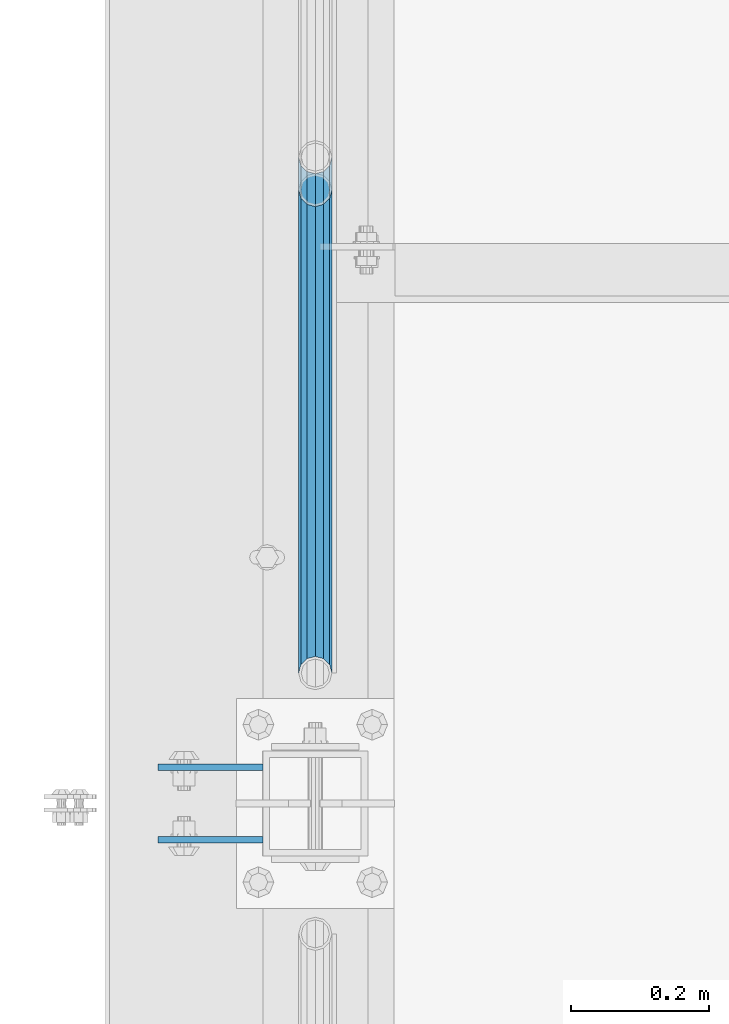
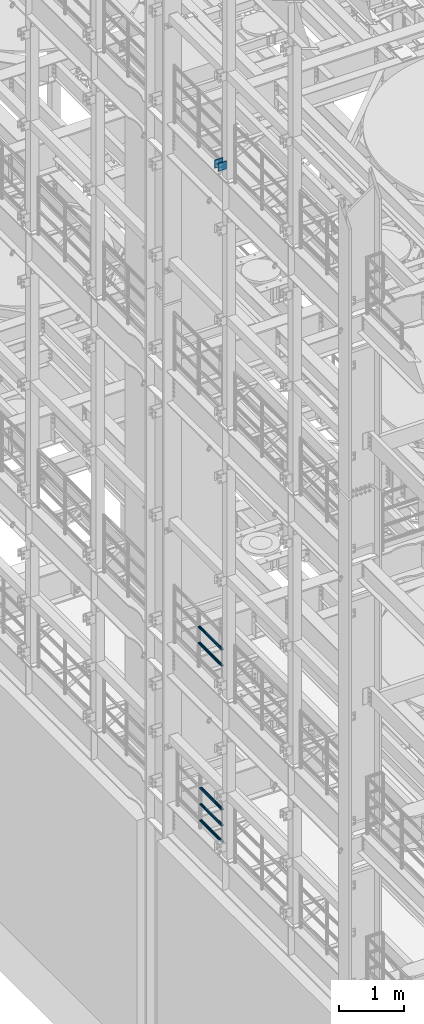
# One storey, part 1231 of 1876: 7 beams, 3 elements without a shape of their own.
"""IFC2X3 building model written with IfcOpenShell, lengths in millimetres."""

from ifc_helpers import new_model, si_unit, frame, origin_with_axes, place, context, subcontext, project, spatial, faceted_brep, material, type_object, element, aggregate, save


model = new_model("IFC2X3")

# Units and contexts
model_context = context("Model", 3, precision=1e-05, world=origin_with_axes())
body_context = subcontext(model_context, "Body", "Model", "MODEL_VIEW")
ifc_project = project(units=[si_unit("LENGTHUNIT", "METRE", prefix="MILLI"), si_unit("AREAUNIT", "SQUARE_METRE"), si_unit("VOLUMEUNIT", "CUBIC_METRE"), si_unit("MASSUNIT", "GRAM", prefix="KILO"), si_unit("TIMEUNIT", "SECOND"), si_unit("PLANEANGLEUNIT", "RADIAN"), si_unit("SOLIDANGLEUNIT", "STERADIAN"), si_unit("THERMODYNAMICTEMPERATUREUNIT", "DEGREE_CELSIUS"), si_unit("LUMINOUSINTENSITYUNIT", "LUMEN")], contexts=[model_context])

# Site, building, storey
site_placement = place(None, origin_with_axes())
site = spatial("IfcSite", under=ifc_project, at=site_placement, CompositionType="ELEMENT")
building_placement = place(site_placement, origin_with_axes())
building = spatial("IfcBuilding", under=site, at=building_placement, Name="Undefined", CompositionType="ELEMENT")
storey_placement = place(building_placement, origin_with_axes())
storey = spatial("IfcBuildingStorey", under=building, at=storey_placement, Name="Undefined", CompositionType="ELEMENT", Elevation=0.0)

# Assembly, beams
assembly_1_placement = place(storey_placement, origin_with_axes())
assembly_1 = element("IfcElementAssembly", 1, at=assembly_1_placement, inside=storey, Name="BEAM", AssemblyPlace="NOTDEFINED", PredefinedType="RIGID_FRAME")
ifc_material_1 = material(Name="STEEL/A36")
beam_type_1 = type_object("IfcBeamType", PredefinedType="NOTDEFINED")
beam_1_placement = place(assembly_1_placement, frame((-76.2000002548894, -455.6125, 18275.3), z_axis=(0.0, 0.0, -1.0), x_axis=(-1.0, 0.0, 0.0)))
beam_1 = element("IfcBeam", 2, at=beam_1_placement, type_object=beam_type_1, material=ifc_material_1, Name="PLATE", context=body_context, shape_type="Brep", body=[
    faceted_brep([(0.0, 4.76249999999982, -76.1999999999998), (3.63797880709171e-12, 4.76249999999982, 76.1999969482422), (152.399993896484, 4.76250000000073, 76.1999969482422), (152.4, 4.76249999999982, -76.1999999999998), (3.63797880709171e-12, -4.76249999999982, 76.1999969482422), (152.399993896484, -4.76250000000073, 76.1999969482422), (0.0, -4.76249999999982, -76.1999999999998), (152.4, -4.76249999999982, -76.1999999999998)], [[[0, 1, 2, 3]], [[4, 5, 2, 1]], [[4, 6, 7, 5]], [[6, 0, 3, 7]], [[5, 7, 3, 2]], [[6, 4, 1, 0]]]),
])
beam_2_placement = place(assembly_1_placement, frame((-76.2000002548894, -560.3875, 18275.3), z_axis=(0.0, 0.0, -1.0), x_axis=(-1.0, 0.0, 0.0)))
beam_2 = element("IfcBeam", 3, at=beam_2_placement, type_object=beam_type_1, material=ifc_material_1, Name="PLATE", context=body_context, shape_type="Brep", body=[
    faceted_brep([(0.0, 4.76249999999982, -76.1999999999998), (3.63797880709171e-12, 4.76249999999982, 76.1999969482422), (152.399993896484, 4.76250000000073, 76.1999969482422), (152.4, 4.76249999999982, -76.1999999999998), (3.63797880709171e-12, -4.76249999999982, 76.1999969482422), (152.399993896484, -4.76250000000073, 76.1999969482422), (0.0, -4.76249999999982, -76.1999999999998), (152.4, -4.76249999999982, -76.1999999999998)], [[[0, 1, 2, 3]], [[4, 5, 2, 1]], [[4, 6, 7, 5]], [[6, 0, 3, 7]], [[5, 7, 3, 2]], [[6, 4, 1, 0]]]),
])
aggregate(assembly_1, [beam_1, beam_2])

assembly_2_placement = place(storey_placement, origin_with_axes())
assembly_2 = element("IfcElementAssembly", 4, at=assembly_2_placement, inside=storey, Name="RAIL", AssemblyPlace="NOTDEFINED", PredefinedType="RIGID_FRAME")
ifc_material_2 = material()
beam_type_2 = type_object("IfcBeamType", Name="PIPE1-1/2SCH40", PredefinedType="NOTDEFINED")
beam_3_placement = place(assembly_2_placement, frame((-1.81898940354586e-12, -318.770000000001, 8620.125), z_axis=(0.0, 0.0, -1.0), x_axis=(0.0, 1.0, 0.0)))
beam_3 = element("IfcBeam", 5, at=beam_3_placement, type_object=beam_type_2, material=ifc_material_2, Name="RAIL", ObjectType="PIPE1-1/2SCH40", context=body_context, shape_type="Brep", body=[
    faceted_brep([(0.0, 24.1299999999992, 0.0), (12.0650000000064, 20.8971929933177, -12.0649999999987), (12.0650000000064, 20.8971929933177, 12.0649999999987), (12.0650000000064, -20.8971929933177, 12.0649999999987), (12.0650000000064, -20.8971929933177, -12.0649999999987), (0.0, -24.1299999999992, 0.0), (20.8971929933249, -12.0650000000005, 20.8971929933177), (20.8971929933249, -12.0650000000005, 15.8661214311796), (15.2545715621445, -17.7076214311801, 10.2235000000001), (12.5151929933249, -20.4470000000001, 0.0), (15.2545715621445, -17.7076214311801, -10.2235000000001), (20.8971929933249, -12.0650000000005, -15.8661214311796), (20.8971929933249, -12.0650000000005, -20.8971929933177), (24.1300000000063, 0.0, -20.4470000000001), (24.1300000000063, 0.0, -24.130000000001), (21.3906214311868, -10.2235000000001, -17.7076214311819), (21.3906214311868, 10.2235000000001, -17.7076214311819), (20.8971929933249, 12.0650000000005, -15.8661214311796), (20.8971929933249, 12.0650000000005, -20.8971929933177), (15.2545715621445, 17.7076214311801, -10.2235000000001), (12.5151929933249, 20.4470000000001, 0.0), (15.2545715621445, 17.7076214311801, 10.2235000000001), (20.8971929933249, 12.0650000000005, 15.8661214311796), (20.8971929933249, 12.0650000000005, 20.8971929933177), (21.3906214311868, 10.2235000000001, 17.7076214311819), (24.1300000000064, 0.0, 20.4470000000001), (24.1300000000064, 0.0, 24.130000000001), (21.3906214311868, -10.2235000000001, 17.7076214311819), (748.982500000002, 24.1300000000001, 0.0), (736.917500000002, 20.8971929933186, -12.0649999999987), (728.085307006683, 12.0649999999996, -20.8971929933177), (748.982500000002, -24.1300000000001, 0.0), (736.917500000002, -20.8971929933186, -12.0649999999987), (736.917500000002, -20.8971929933186, 12.0649999999987), (728.085307006683, -12.0649999999996, 20.8971929933177), (728.085307006683, -12.0649999999996, -20.8971929933177), (724.852500000002, 0.0, -24.130000000001), (727.591878568821, 10.2235000000001, -17.7076214311819), (724.852500000002, 0.0, -20.4470000000001), (728.085307006683, 12.0649999999996, -15.8661214311796), (728.085307006683, -12.0649999999996, -15.8661214311796), (727.591878568821, -10.2235000000001, -17.7076214311819), (733.727928437864, -17.7076214311801, -10.2235000000001), (736.467307006683, -20.4470000000001, 0.0), (733.727928437864, -17.7076214311801, 10.2235000000001), (728.085307006683, -12.0649999999996, 15.8661214311796), (727.591878568821, -10.2235000000001, 17.7076214311819), (724.852500000002, 0.0, 20.4470000000001), (724.852500000002, 0.0, 24.130000000001), (728.085307006683, 12.0649999999996, 20.8971929933177), (736.917500000002, 20.8971929933186, 12.0649999999987), (728.085307006683, 12.0649999999996, 15.8661214311796), (733.727928437864, 17.7076214311801, 10.2235000000001), (736.467307006683, 20.4470000000001, 0.0), (733.727928437864, 17.7076214311801, -10.2235000000001), (727.591878568821, 10.2235000000001, 17.7076214311819)], [[[0, 1, 2]], [[3, 4, 5]], [[6, 7, 8, 9, 10, 11, 12, 4, 3]], [[13, 14, 12, 11, 15]], [[16, 17, 18, 14, 13]], [[2, 1, 18, 17, 19, 20, 21, 22, 23]], [[23, 22, 24, 25, 26]], [[26, 25, 27, 7, 6]], [[1, 0, 28, 29]], [[18, 1, 29, 30]], [[31, 32, 33]], [[6, 3, 33, 34]], [[3, 5, 31, 33]], [[5, 4, 32, 31]], [[4, 12, 35, 32]], [[12, 14, 36, 35]], [[14, 18, 30, 36]], [[37, 38, 36, 30, 39]], [[40, 35, 36, 38, 41]], [[33, 32, 35, 40, 42, 43, 44, 45, 34]], [[34, 45, 46, 47, 48]], [[26, 6, 34, 48]], [[2, 23, 49, 50]], [[23, 26, 48, 49]], [[0, 2, 50, 28]], [[28, 50, 29]], [[49, 51, 52, 53, 54, 39, 30, 29, 50]], [[48, 47, 55, 51, 49]], [[25, 24, 55, 47]], [[55, 24, 22, 21, 52, 51]], [[21, 20, 53, 52]], [[20, 19, 54, 53]], [[19, 17, 16, 37, 39, 54]], [[16, 13, 38, 37]], [[13, 15, 41, 38]], [[41, 15, 11, 10, 42, 40]], [[10, 9, 43, 42]], [[9, 8, 44, 43]], [[8, 7, 27, 46, 45, 44]], [[27, 25, 47, 46]]]),
])
beam_4_placement = place(assembly_2_placement, frame((-1.81898940354586e-12, -318.770000000001, 8924.925), z_axis=(0.0, 0.0, -1.0), x_axis=(0.0, 1.0, 0.0)))
beam_4 = element("IfcBeam", 6, at=beam_4_placement, type_object=beam_type_2, material=ifc_material_2, Name="RAIL", ObjectType="PIPE1-1/2SCH40", context=body_context, shape_type="Brep", body=[
    faceted_brep([(0.0, 24.1299999999992, 0.0), (12.0650000000064, 20.8971929933177, -12.0649999999987), (12.0650000000064, 20.8971929933177, 12.0649999999987), (12.0650000000064, -20.8971929933177, 12.0649999999987), (12.0650000000064, -20.8971929933177, -12.0649999999987), (0.0, -24.1299999999992, 0.0), (20.8971929933249, -12.0650000000005, 20.8971929933177), (20.8971929933249, -12.0650000000005, 15.8661214311796), (15.2545715621445, -17.7076214311801, 10.2235000000001), (12.5151929933249, -20.4470000000001, 0.0), (15.2545715621445, -17.7076214311801, -10.2235000000001), (20.8971929933249, -12.0650000000005, -15.8661214311796), (20.8971929933249, -12.0650000000005, -20.8971929933177), (24.1300000000063, 0.0, -20.4470000000001), (24.1300000000063, 0.0, -24.130000000001), (21.3906214311868, -10.2235000000001, -17.7076214311819), (21.3906214311868, 10.2235000000001, -17.7076214311819), (20.8971929933249, 12.0650000000005, -15.8661214311796), (20.8971929933249, 12.0650000000005, -20.8971929933177), (15.2545715621445, 17.7076214311801, -10.2235000000001), (12.5151929933249, 20.4470000000001, 0.0), (15.2545715621445, 17.7076214311801, 10.2235000000001), (20.8971929933249, 12.0650000000005, 15.8661214311796), (20.8971929933249, 12.0650000000005, 20.8971929933177), (21.3906214311868, 10.2235000000001, 17.7076214311819), (24.1300000000064, 0.0, 20.4470000000001), (24.1300000000064, 0.0, 24.130000000001), (21.3906214311868, -10.2235000000001, 17.7076214311819), (748.982500000002, 24.1300000000001, 0.0), (736.917500000002, 20.8971929933186, -12.0649999999987), (728.085307006683, 12.0649999999996, -20.8971929933177), (748.982500000002, -24.1300000000001, 0.0), (736.917500000002, -20.8971929933186, -12.0649999999987), (736.917500000002, -20.8971929933186, 12.0649999999987), (728.085307006683, -12.0649999999996, 20.8971929933177), (728.085307006683, -12.0649999999996, -20.8971929933177), (724.852500000002, 0.0, -24.130000000001), (727.591878568821, 10.2235000000001, -17.7076214311819), (724.852500000002, 0.0, -20.4470000000001), (728.085307006683, 12.0649999999996, -15.8661214311796), (728.085307006683, -12.0649999999996, -15.8661214311796), (727.591878568821, -10.2235000000001, -17.7076214311819), (733.727928437864, -17.7076214311801, -10.2235000000001), (736.467307006683, -20.4470000000001, 0.0), (733.727928437864, -17.7076214311801, 10.2235000000001), (728.085307006683, -12.0649999999996, 15.8661214311796), (727.591878568821, -10.2235000000001, 17.7076214311819), (724.852500000002, 0.0, 20.4470000000001), (724.852500000002, 0.0, 24.130000000001), (728.085307006683, 12.0649999999996, 20.8971929933177), (736.917500000002, 20.8971929933186, 12.0649999999987), (728.085307006683, 12.0649999999996, 15.8661214311796), (733.727928437864, 17.7076214311801, 10.2235000000001), (736.467307006683, 20.4470000000001, 0.0), (733.727928437864, 17.7076214311801, -10.2235000000001), (727.591878568821, 10.2235000000001, 17.7076214311819)], [[[0, 1, 2]], [[3, 4, 5]], [[6, 7, 8, 9, 10, 11, 12, 4, 3]], [[13, 14, 12, 11, 15]], [[16, 17, 18, 14, 13]], [[2, 1, 18, 17, 19, 20, 21, 22, 23]], [[23, 22, 24, 25, 26]], [[26, 25, 27, 7, 6]], [[1, 0, 28, 29]], [[18, 1, 29, 30]], [[31, 32, 33]], [[6, 3, 33, 34]], [[3, 5, 31, 33]], [[5, 4, 32, 31]], [[4, 12, 35, 32]], [[12, 14, 36, 35]], [[14, 18, 30, 36]], [[37, 38, 36, 30, 39]], [[40, 35, 36, 38, 41]], [[33, 32, 35, 40, 42, 43, 44, 45, 34]], [[34, 45, 46, 47, 48]], [[26, 6, 34, 48]], [[2, 23, 49, 50]], [[23, 26, 48, 49]], [[0, 2, 50, 28]], [[28, 50, 29]], [[49, 51, 52, 53, 54, 39, 30, 29, 50]], [[48, 47, 55, 51, 49]], [[25, 24, 55, 47]], [[55, 24, 22, 21, 52, 51]], [[21, 20, 53, 52]], [[20, 19, 54, 53]], [[19, 17, 16, 37, 39, 54]], [[16, 13, 38, 37]], [[13, 15, 41, 38]], [[41, 15, 11, 10, 42, 40]], [[10, 9, 43, 42]], [[9, 8, 44, 43]], [[8, 7, 27, 46, 45, 44]], [[27, 25, 47, 46]]]),
])
aggregate(assembly_2, [beam_3, beam_4])

assembly_3_placement = place(storey_placement, origin_with_axes())
assembly_3 = element("IfcElementAssembly", 7, at=assembly_3_placement, inside=storey, Name="RAIL", AssemblyPlace="NOTDEFINED", PredefinedType="RIGID_FRAME")
beam_5_placement = place(assembly_3_placement, frame((1.71398895076891e-10, -318.77, 5292.72499999952), z_axis=(0.0, -8.42999999986204e-06, 0.999999999964468), x_axis=(0.0, 0.999999999964468, 8.43000000018809e-06)))
beam_5 = element("IfcBeam", 8, at=beam_5_placement, type_object=beam_type_2, material=ifc_material_2, Name="RAIL", ObjectType="PIPE1-1/2SCH40", context=body_context, shape_type="Brep", body=[
    faceted_brep([(680.442814874983, -12.0649999999996, 20.8971929933068), (680.44277246305, -12.0649999999277, 15.8661214312397), (679.949359549034, -10.2235000000001, 17.7076214311674), (677.210004073059, 2.72848410531878e-12, 20.4469999999883), (677.210035120749, 2.72848410531878e-12, 24.1299999999883), (679.949359548996, 10.2235000000001, 17.7076214311674), (680.44277246305, 12.0650000000714, 15.866121431096), (680.442814874983, 12.0649999999996, 20.8971929933068), (701.33983170571, 24.1300000000001, -1.45519152283669e-11), (689.27493341323, 20.8971929933186, 12.0649999999878), (689.27472999733, 20.8971929933186, -12.0650000000151), (686.085346327061, 17.7076214311801, 10.2234999999873), (688.824638711873, 20.4470000000001, -1.36424205265939e-11), (686.085173958852, 17.7076214311801, -10.2235000000137), (680.442504960242, 12.0650000000714, -15.8661214311223), (680.442462548309, 12.0649999999996, -20.8971929933323), (679.949060998498, 10.2235000000001, -17.7076214311946), (677.20965933664, 0.0, -20.4470000000147), (677.20962828895, 0.0, -24.1300000000147), (680.442504960242, -12.0649999999277, -15.866121431266), (680.442462548309, -12.0649999999996, -20.8971929933323), (679.949060998536, -10.2235000000001, -17.7076214311946), (701.33983170571, -24.1299999999283, -1.45519152283669e-11), (689.27472999733, -20.8971929933186, -12.0650000000151), (689.27493341323, -20.8971929933186, 12.0649999999878), (686.085173958994, -17.7076214311801, -10.2235000000137), (688.824638712016, -20.4470000000001, -1.36424205265939e-11), (686.085346327204, -17.7076214311801, 10.2234999999873), (12.0648982924813, -20.8971929933186, -12.0650000000005), (20.8970168307269, -12.0649999999996, -20.8971929933195), (0.0, 24.1299999999992, 0.0), (12.0648982924813, 20.8971929933186, -12.0650000000005), (12.065101708381, 20.8971929933186, 12.0650000000005), (20.897369157401, 12.0649999999996, 20.8971929933205), (24.1302034167611, 7.18500814400613e-11, 24.1300000000019), (20.8970168307269, 12.0649999999996, -20.8971929933195), (24.1297965849608, 0.0, -24.130000000001), (24.1298276326506, 0.0, -20.447000000001), (20.8970592426604, -12.0649999999277, -15.8661214312533), (21.390472156676, -10.2235000000001, -17.7076214311819), (21.3904721567151, 10.2235000000001, -17.7076214311819), (20.8970592426604, 12.0650000000714, -15.8661214311096), (15.2544853786503, 17.7076214311801, -10.2235000000001), (12.5151929933249, 20.4470000000001, 0.0), (15.2546577468602, 17.7076214311801, 10.223500000001), (20.8973267454676, 12.0650000000714, 15.8661214311096), (21.3907707072121, 10.2235000000001, 17.7076214311819), (24.1301723690713, 7.18500814400613e-11, 20.447000000001), (21.390770707173, -10.2235000000001, 17.7076214311819), (20.8973267454676, -12.0649999999277, 15.8661214312533), (20.897369157401, -12.0649999999996, 20.8971929933205), (12.065101708381, -20.8971929933186, 12.0650000000005), (0.0, -24.1299999999992, 0.0), (15.2546577467156, -17.7076214311801, 10.223500000001), (12.5151929933249, -20.4470000000001, 0.0), (15.2544853785057, -17.7076214311801, -10.2235000000001)], [[[0, 1, 2, 3, 4]], [[4, 3, 5, 6, 7]], [[8, 9, 10]], [[7, 6, 11, 12, 13, 14, 15, 10, 9]], [[16, 17, 18, 15, 14]], [[19, 20, 18, 17, 21]], [[22, 23, 24]], [[24, 23, 20, 19, 25, 26, 27, 1, 0]], [[28, 29, 20, 23]], [[30, 31, 32]], [[33, 34, 4, 7]], [[32, 33, 7, 9]], [[30, 32, 9, 8]], [[31, 30, 8, 10]], [[35, 31, 10, 15]], [[36, 35, 15, 18]], [[29, 36, 18, 20]], [[37, 36, 29, 38, 39]], [[40, 41, 35, 36, 37]], [[32, 31, 35, 41, 42, 43, 44, 45, 33]], [[33, 45, 46, 47, 34]], [[34, 47, 48, 49, 50]], [[34, 50, 0, 4]], [[50, 51, 24, 0]], [[51, 52, 22, 24]], [[52, 28, 23, 22]], [[51, 28, 52]], [[50, 49, 53, 54, 55, 38, 29, 28, 51]], [[55, 54, 26, 25]], [[21, 39, 38, 55, 25, 19]], [[37, 39, 21, 17]], [[40, 37, 17, 16]], [[42, 41, 40, 16, 14, 13]], [[43, 42, 13, 12]], [[44, 43, 12, 11]], [[5, 46, 45, 44, 11, 6]], [[47, 46, 5, 3]], [[48, 47, 3, 2]], [[53, 49, 48, 2, 1, 27]], [[54, 53, 27, 26]]]),
])
beam_6_placement = place(assembly_3_placement, frame((7.03721525496803e-11, 382.569831680701, 5597.53091229414), z_axis=(0.0, 7.91400000045761e-06, -0.999999999968684), x_axis=(0.0, -0.999999999968684, -7.91400000071008e-06)))
beam_6 = element("IfcBeam", 9, at=beam_6_placement, type_object=beam_type_2, material=ifc_material_2, Name="RAIL", ObjectType="PIPE1-1/2SCH40", context=body_context, shape_type="Brep", body=[
    faceted_brep([(0.0, 24.1299999999992, 0.0), (12.0648982924813, 20.8971929933186, -12.0650000000005), (12.065101708381, 20.8971929933186, 12.0650000000005), (12.065101708381, -20.8971929933186, 12.0650000000005), (12.0648982924813, -20.8971929933186, -12.0650000000005), (0.0, -24.1299999999992, 0.0), (20.897369157401, -12.0649999999996, 20.8971929933205), (20.8973267454676, -12.0649999999277, 15.8661214312533), (15.2546577467156, -17.7076214311801, 10.223500000001), (12.5151929933249, -20.4470000000001, 0.0), (15.2544853785057, -17.7076214311801, -10.2235000000001), (20.8970592426604, -12.0649999999277, -15.8661214312533), (20.8970168307269, -12.0649999999996, -20.8971929933195), (24.1298276326506, 0.0, -20.447000000001), (24.1297965849608, 0.0, -24.130000000001), (21.390472156676, -10.2235000000001, -17.7076214311819), (21.3904721567151, 10.2235000000001, -17.7076214311819), (20.8970592426604, 12.0650000000714, -15.8661214311096), (20.8970168307269, 12.0649999999996, -20.8971929933195), (15.2544853786503, 17.7076214311801, -10.2235000000001), (12.5151929933249, 20.4470000000001, 0.0), (15.2546577468602, 17.7076214311801, 10.223500000001), (20.8973267454676, 12.0650000000714, 15.8661214311096), (20.897369157401, 12.0649999999996, 20.8971929933205), (21.3907707072121, 10.2235000000001, 17.7076214311819), (24.1301723690713, 7.18500814400613e-11, 20.447000000001), (24.1302034167611, 7.18500814400613e-11, 24.1300000000019), (21.390770707173, -10.2235000000001, 17.7076214311819), (701.33983170571, 24.1300000000001, -1.45519152283669e-11), (689.27472999733, 20.8971929933186, -12.0650000000151), (680.442462548309, 12.0649999999996, -20.8971929933323), (701.33983170571, -24.1299999999283, -1.45519152283669e-11), (689.27472999733, -20.8971929933186, -12.0650000000151), (689.27493341323, -20.8971929933186, 12.0649999999878), (680.442814874983, -12.0649999999996, 20.8971929933068), (680.442462548309, -12.0649999999996, -20.8971929933323), (677.20962828895, 0.0, -24.1300000000147), (679.949060998498, 10.2235000000001, -17.7076214311946), (677.20965933664, 0.0, -20.4470000000147), (680.442504960242, 12.0650000000714, -15.8661214311223), (680.442504960242, -12.0649999999277, -15.866121431266), (679.949060998536, -10.2235000000001, -17.7076214311946), (686.085173958994, -17.7076214311801, -10.2235000000137), (688.824638712016, -20.4470000000001, -1.36424205265939e-11), (686.085346327204, -17.7076214311801, 10.2234999999873), (680.44277246305, -12.0649999999277, 15.8661214312397), (679.949359549034, -10.2235000000001, 17.7076214311674), (677.210004073059, 2.72848410531878e-12, 20.4469999999883), (677.210035120749, 2.72848410531878e-12, 24.1299999999883), (680.442814874983, 12.0649999999996, 20.8971929933068), (689.27493341323, 20.8971929933186, 12.0649999999878), (680.44277246305, 12.0650000000714, 15.866121431096), (686.085346327061, 17.7076214311801, 10.2234999999873), (688.824638711873, 20.4470000000001, -1.36424205265939e-11), (686.085173958852, 17.7076214311801, -10.2235000000137), (679.949359548996, 10.2235000000001, 17.7076214311674)], [[[0, 1, 2]], [[3, 4, 5]], [[6, 7, 8, 9, 10, 11, 12, 4, 3]], [[13, 14, 12, 11, 15]], [[16, 17, 18, 14, 13]], [[2, 1, 18, 17, 19, 20, 21, 22, 23]], [[23, 22, 24, 25, 26]], [[26, 25, 27, 7, 6]], [[1, 0, 28, 29]], [[18, 1, 29, 30]], [[31, 32, 33]], [[6, 3, 33, 34]], [[3, 5, 31, 33]], [[5, 4, 32, 31]], [[4, 12, 35, 32]], [[12, 14, 36, 35]], [[14, 18, 30, 36]], [[37, 38, 36, 30, 39]], [[40, 35, 36, 38, 41]], [[33, 32, 35, 40, 42, 43, 44, 45, 34]], [[34, 45, 46, 47, 48]], [[26, 6, 34, 48]], [[2, 23, 49, 50]], [[23, 26, 48, 49]], [[0, 2, 50, 28]], [[28, 50, 29]], [[49, 51, 52, 53, 54, 39, 30, 29, 50]], [[48, 47, 55, 51, 49]], [[25, 24, 55, 47]], [[55, 24, 22, 21, 52, 51]], [[21, 20, 53, 52]], [[20, 19, 54, 53]], [[19, 17, 16, 37, 39, 54]], [[16, 13, 38, 37]], [[13, 15, 41, 38]], [[41, 15, 11, 10, 42, 40]], [[10, 9, 43, 42]], [[9, 8, 44, 43]], [[8, 7, 27, 46, 45, 44]], [[27, 25, 47, 46]]]),
])
beam_7_placement = place(assembly_3_placement, frame((7.03721525496803e-11, 382.569831680701, 5902.33091229485), z_axis=(0.0, 7.91400000045761e-06, -0.999999999968684), x_axis=(0.0, -0.999999999968684, -7.91400000071008e-06)))
beam_7 = element("IfcBeam", 10, at=beam_7_placement, type_object=beam_type_2, material=ifc_material_2, Name="RAIL", ObjectType="PIPE1-1/2SCH40", context=body_context, shape_type="Brep", body=[
    faceted_brep([(0.0, 24.1299999999992, 0.0), (12.0648982924813, 20.8971929933186, -12.0650000000005), (12.065101708381, 20.8971929933186, 12.0650000000005), (12.065101708381, -20.8971929933186, 12.0650000000005), (12.0648982924813, -20.8971929933186, -12.0650000000005), (0.0, -24.1299999999992, 0.0), (20.897369157401, -12.0649999999996, 20.8971929933205), (20.8973267454676, -12.0649999999277, 15.8661214312533), (15.2546577467156, -17.7076214311801, 10.223500000001), (12.5151929933249, -20.4470000000001, 0.0), (15.2544853785057, -17.7076214311801, -10.2235000000001), (20.8970592426604, -12.0649999999277, -15.8661214312533), (20.8970168307269, -12.0649999999996, -20.8971929933195), (24.1298276326506, 0.0, -20.447000000001), (24.1297965849608, 0.0, -24.130000000001), (21.390472156676, -10.2235000000001, -17.7076214311819), (21.3904721567151, 10.2235000000001, -17.7076214311819), (20.8970592426604, 12.0650000000714, -15.8661214311096), (20.8970168307269, 12.0649999999996, -20.8971929933195), (15.2544853786503, 17.7076214311801, -10.2235000000001), (12.5151929933249, 20.4470000000001, 0.0), (15.2546577468602, 17.7076214311801, 10.223500000001), (20.8973267454676, 12.0650000000714, 15.8661214311096), (20.897369157401, 12.0649999999996, 20.8971929933205), (21.3907707072121, 10.2235000000001, 17.7076214311819), (24.1301723690713, 7.18500814400613e-11, 20.447000000001), (24.1302034167611, 7.18500814400613e-11, 24.1300000000019), (21.390770707173, -10.2235000000001, 17.7076214311819), (701.33983170571, 24.1300000000001, -1.45519152283669e-11), (689.27472999733, 20.8971929933186, -12.0650000000151), (680.442462548309, 12.0649999999996, -20.8971929933323), (701.33983170571, -24.1299999999283, -1.45519152283669e-11), (689.27472999733, -20.8971929933186, -12.0650000000151), (689.27493341323, -20.8971929933186, 12.0649999999878), (680.442814874983, -12.0649999999996, 20.8971929933068), (680.442462548309, -12.0649999999996, -20.8971929933323), (677.20962828895, 0.0, -24.1300000000147), (679.949060998498, 10.2235000000001, -17.7076214311946), (677.20965933664, 0.0, -20.4470000000147), (680.442504960242, 12.0650000000714, -15.8661214311223), (680.442504960242, -12.0649999999277, -15.866121431266), (679.949060998536, -10.2235000000001, -17.7076214311946), (686.085173958994, -17.7076214311801, -10.2235000000137), (688.824638712016, -20.4470000000001, -1.36424205265939e-11), (686.085346327204, -17.7076214311801, 10.2234999999873), (680.44277246305, -12.0649999999277, 15.8661214312397), (679.949359549034, -10.2235000000001, 17.7076214311674), (677.210004073059, 2.72848410531878e-12, 20.4469999999883), (677.210035120749, 2.72848410531878e-12, 24.1299999999883), (680.442814874983, 12.0649999999996, 20.8971929933068), (689.27493341323, 20.8971929933186, 12.0649999999878), (680.44277246305, 12.0650000000714, 15.866121431096), (686.085346327061, 17.7076214311801, 10.2234999999873), (688.824638711873, 20.4470000000001, -1.36424205265939e-11), (686.085173958852, 17.7076214311801, -10.2235000000137), (679.949359548996, 10.2235000000001, 17.7076214311674)], [[[0, 1, 2]], [[3, 4, 5]], [[6, 7, 8, 9, 10, 11, 12, 4, 3]], [[13, 14, 12, 11, 15]], [[16, 17, 18, 14, 13]], [[2, 1, 18, 17, 19, 20, 21, 22, 23]], [[23, 22, 24, 25, 26]], [[26, 25, 27, 7, 6]], [[1, 0, 28, 29]], [[18, 1, 29, 30]], [[31, 32, 33]], [[6, 3, 33, 34]], [[3, 5, 31, 33]], [[5, 4, 32, 31]], [[4, 12, 35, 32]], [[12, 14, 36, 35]], [[14, 18, 30, 36]], [[37, 38, 36, 30, 39]], [[40, 35, 36, 38, 41]], [[33, 32, 35, 40, 42, 43, 44, 45, 34]], [[34, 45, 46, 47, 48]], [[26, 6, 34, 48]], [[2, 23, 49, 50]], [[23, 26, 48, 49]], [[0, 2, 50, 28]], [[28, 50, 29]], [[49, 51, 52, 53, 54, 39, 30, 29, 50]], [[48, 47, 55, 51, 49]], [[25, 24, 55, 47]], [[55, 24, 22, 21, 52, 51]], [[21, 20, 53, 52]], [[20, 19, 54, 53]], [[19, 17, 16, 37, 39, 54]], [[16, 13, 38, 37]], [[13, 15, 41, 38]], [[41, 15, 11, 10, 42, 40]], [[10, 9, 43, 42]], [[9, 8, 44, 43]], [[8, 7, 27, 46, 45, 44]], [[27, 25, 47, 46]]]),
])
aggregate(assembly_3, [beam_5, beam_6, beam_7])

save(model, "model.ifc")
